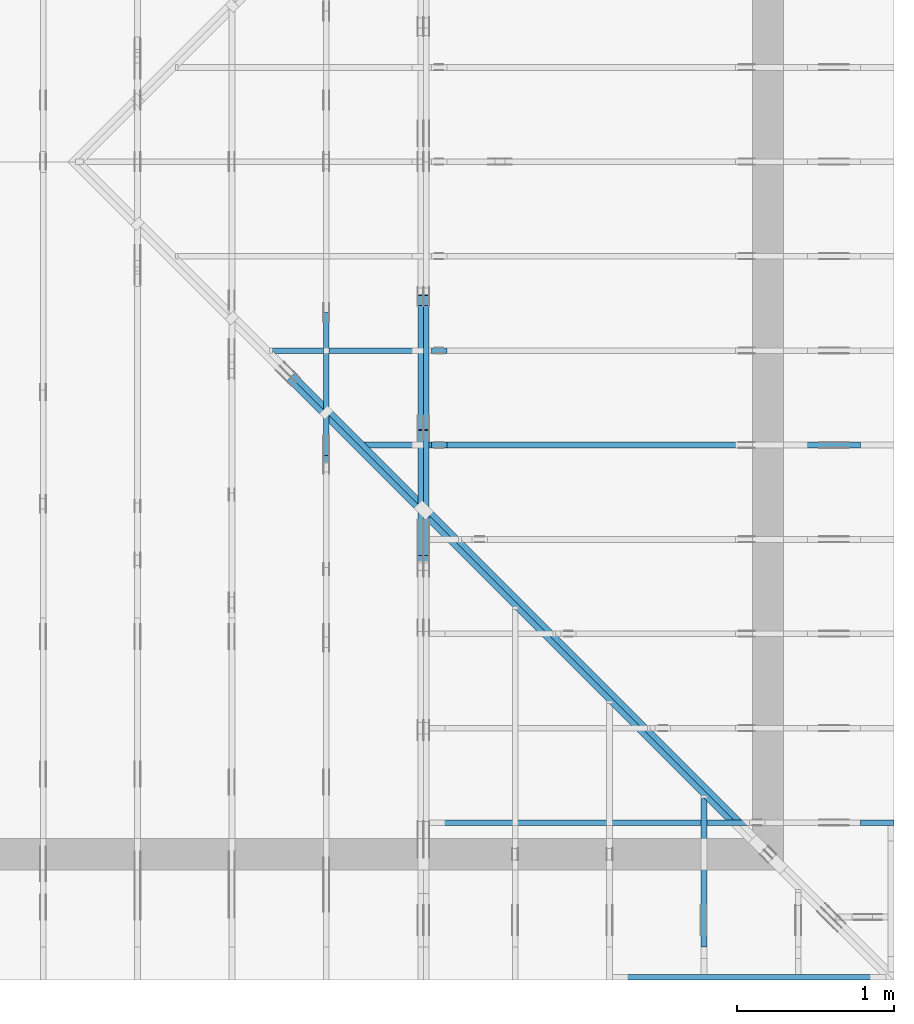
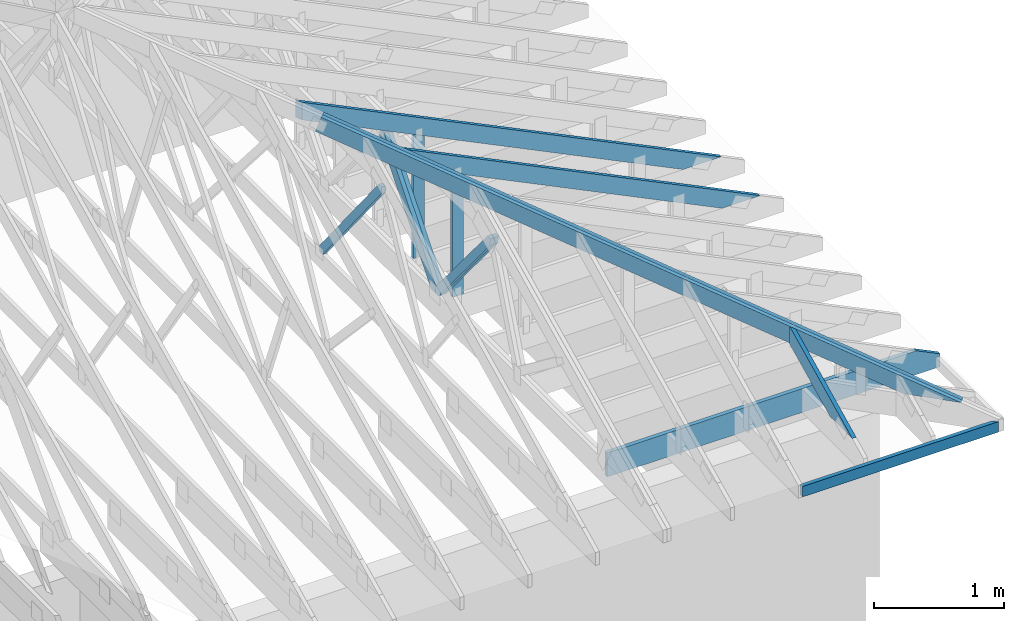
# One storey, part 30 of 159: 14 members, 8 elements without a shape of their own.
"""IFC2X3 building model written with IfcOpenShell, lengths in millimetres."""

from ifc_helpers import new_model, si_unit, frame, origin, origin_with_axes, origin_2d, place, context, project, spatial, faceted_brep, element, aggregate, save


model = new_model("IFC2X3")

# Units and contexts
model_context = context("Model", 3, precision=1e-05, world=origin())
plan_context = context("Plan", 2, precision=1e-05, world=origin_2d())
ifc_project = project(units=[si_unit("LENGTHUNIT", "METRE", prefix="MILLI"), si_unit("AREAUNIT", "SQUARE_METRE"), si_unit("VOLUMEUNIT", "CUBIC_METRE"), si_unit("SOLIDANGLEUNIT", "STERADIAN"), si_unit("PLANEANGLEUNIT", "RADIAN"), si_unit("MASSUNIT", "GRAM"), si_unit("TIMEUNIT", "SECOND"), si_unit("THERMODYNAMICTEMPERATUREUNIT", "DEGREE_CELSIUS"), si_unit("LUMINOUSINTENSITYUNIT", "LUMEN")], contexts=[model_context, plan_context])

# Site, building, storey
site_placement = place(None, origin_with_axes())
site = spatial("IfcSite", under=ifc_project, at=site_placement, CompositionType="ELEMENT")
building_placement = place(site_placement, origin_with_axes())
building = spatial("IfcBuilding", under=site, at=building_placement, Name="Plan 1", CompositionType="ELEMENT")
storey_placement = place(building_placement, origin_with_axes())
storey = spatial("IfcBuildingStorey", under=building, at=storey_placement, Name="Etasje 1", CompositionType="ELEMENT", Elevation=0.0)

# Assembly, members
assembly_1_placement = place(storey_placement, frame((18074.541652722903, -699.9989301294845, 4.408582873760558e-15), z_axis=(-1.0, 1.836909530733566e-16, 6.123031769111886e-17), x_axis=(-1.836909530733566e-16, -1.0, 0.0)))
assembly_1 = element("IfcElementAssembly", 1, at=assembly_1_placement, inside=storey, Name="V5 (30)", AssemblyPlace="FACTORY", PredefinedType="TRUSS")
member_1_placement = place(assembly_1_placement, frame((-2678.1204012406793, 1271.1402097233088, -36.0), z_axis=(0.0, 0.0, 1.0), x_axis=(-0.6383914022226188, -0.7697119055648279, 0.0)))
member_1 = element("IfcMember", 2, at=member_1_placement, Name="V5-D38", context=model_context, shape_type="Brep", body=[
    faceted_brep([(1301.1849955110679, 73.00008611311387, 36.0), (62.15342317344346, 73.00008611311387, 36.0), (1.925760545873345e-05, 36.500065057071424, 36.0), (30.2728013912257, 1.0793038654810516e-05, 36.0), (1274.7302246285853, 1.0793038654810516e-05, 36.0), (1331.4577776446881, 36.500065057071424, 36.0), (62.15342317344346, 73.00008611311387, 7.611347693000984e-15), (1301.1849955110679, 73.00008611311387, 1.5934394130011952e-13), (1331.4577776446881, 36.500065057071424, 1.630511654349907e-13), (1274.7302246285853, 1.0793038654810516e-05, 1.561042732489592e-13), (30.2728013912257, 1.0793038654810516e-05, 3.707226493169789e-15), (1.925760545873345e-05, 36.500065057071424, 2.358298600416948e-21), (-3.552713678800501e-15, 36.500040380931296, 3.944304526105059e-31), (-1.7763568394002505e-15, 36.500040380931296, 36.0), (62.15334871144181, 73.00004038003819, 36.0), (62.15334871144181, 73.00004038003819, 1.9721522630525295e-30), (30.272737128310837, 4.038003907957943e-05, -1.9721522630525295e-31), (30.27273712831084, 4.038003908135579e-05, 36.0), (-3.552713678800501e-15, 36.50004038093129, 36.0), (-3.552713678800501e-15, 36.50004038093129, 3.944304526105059e-31), (1274.7301805652774, 4.038003774819817e-05, -1.9033096714954924e-30), (1274.7301805652774, 4.0380037750402464e-05, 36.0), (30.272737128310837, 4.038003908429828e-05, 36.0), (30.272737128310837, 4.038003908209399e-05, -4.520029685691473e-32), (1331.4577705691959, 36.50004038003976, -1.9644201173045402e-29), (1331.4577705691959, 36.50004038003976, 36.0), (1274.7301805652774, 4.038003805817425e-05, 36.0), (1274.7301805652774, 4.038003805817425e-05, -1.9228473416014148e-29), (1301.1850334416263, 73.00004038003783, 0.0), (1301.1850334416263, 73.00004038003783, 36.0), (1331.4577705691959, 36.500040380039536, 36.0), (1331.4577705691959, 36.500040380039536, 0.0), (62.15334871144182, 73.00004038003819, 1.5777218104420236e-30), (62.15334871144182, 73.00004038003819, 36.0), (1301.1850334416263, 73.00004038003783, 36.0), (1301.1850334416263, 73.00004038003783, 7.099748146989106e-30)], [[[0, 1, 2, 3, 4, 5]], [[6, 7, 8, 9, 10, 11]], [[12, 13, 14, 15]], [[16, 17, 18, 19]], [[20, 21, 22, 23]], [[24, 25, 26, 27]], [[28, 29, 30, 31]], [[32, 33, 34, 35]]]),
])
member_2_placement = place(assembly_1_placement, frame((-2678.1204012406793, 1271.1402097233088, -72.0), z_axis=(0.0, 0.0, 1.0), x_axis=(-0.6383914022226188, -0.7697119055648279, 0.0)))
member_2 = element("IfcMember", 3, at=member_2_placement, Name="V5-D38", context=model_context, shape_type="Brep", body=[
    faceted_brep([(1301.1849955110679, 73.00008611311387, 36.0), (62.15342317344346, 73.00008611311387, 36.0), (1.925760545873345e-05, 36.500065057071424, 36.0), (30.2728013912257, 1.0793038654810516e-05, 36.0), (1274.7302246285853, 1.0793038654810516e-05, 36.0), (1331.4577776446881, 36.500065057071424, 36.0), (62.15342317344346, 73.00008611311387, 7.611347693000984e-15), (1301.1849955110679, 73.00008611311387, 1.5934394130011952e-13), (1331.4577776446881, 36.500065057071424, 1.630511654349907e-13), (1274.7302246285853, 1.0793038654810516e-05, 1.561042732489592e-13), (30.2728013912257, 1.0793038654810516e-05, 3.707226493169789e-15), (1.925760545873345e-05, 36.500065057071424, 2.358298600416948e-21), (-3.552713678800501e-15, 36.500040380931296, 3.944304526105059e-31), (-1.7763568394002505e-15, 36.500040380931296, 36.0), (62.15334871144181, 73.00004038003819, 36.0), (62.15334871144181, 73.00004038003819, 1.9721522630525295e-30), (30.272737128310837, 4.038003907957943e-05, -1.9721522630525295e-31), (30.27273712831084, 4.038003908135579e-05, 36.0), (-3.552713678800501e-15, 36.50004038093129, 36.0), (-3.552713678800501e-15, 36.50004038093129, 3.944304526105059e-31), (1274.7301805652774, 4.038003774819817e-05, -1.9033096714954924e-30), (1274.7301805652774, 4.0380037750402464e-05, 36.0), (30.272737128310837, 4.038003908429828e-05, 36.0), (30.272737128310837, 4.038003908209399e-05, -4.520029685691473e-32), (1331.4577705691959, 36.50004038003976, -1.9644201173045402e-29), (1331.4577705691959, 36.50004038003976, 36.0), (1274.7301805652774, 4.038003805817425e-05, 36.0), (1274.7301805652774, 4.038003805817425e-05, -1.9228473416014148e-29), (1301.1850334416263, 73.00004038003783, 0.0), (1301.1850334416263, 73.00004038003783, 36.0), (1331.4577705691959, 36.500040380039536, 36.0), (1331.4577705691959, 36.500040380039536, 0.0), (62.15334871144182, 73.00004038003819, 1.5777218104420236e-30), (62.15334871144182, 73.00004038003819, 36.0), (1301.1850334416263, 73.00004038003783, 36.0), (1301.1850334416263, 73.00004038003783, 7.099748146989106e-30)], [[[0, 1, 2, 3, 4, 5]], [[6, 7, 8, 9, 10, 11]], [[12, 13, 14, 15]], [[16, 17, 18, 19]], [[20, 21, 22, 23]], [[24, 25, 26, 27]], [[28, 29, 30, 31]], [[32, 33, 34, 35]]]),
])
member_3_placement = place(assembly_1_placement, frame((-4387.724314539022, 1216.557586970512, -36.0), z_axis=(0.0, 0.0, 1.0), x_axis=(0.6383914022217934, -0.7697119055655125, 0.0)))
member_3 = element("IfcMember", 4, at=member_3_placement, Name="V5-D8", context=model_context, shape_type="Brep", body=[
    faceted_brep([(1285.0975247561496, 98.00015613100459, 36.0), (40.640101518789834, 98.00015613100459, 36.0), (5.104694082547212e-06, 49.00016516084588, 36.0), (46.3601114727885, 0.0, 36.0), (1290.8176670776807, 0.0, 36.0), (1331.4577634917764, 49.00016516084588, 36.0), (40.640101518789834, 98.00015613100459, 4.9768126539896475e-15), (1285.0975247561496, 98.00015613100459, 1.5737385940977904e-13), (1331.4577634917764, 49.00016516084588, 1.6305116370181615e-13), (1290.8176670776807, 0.0, 1.580743516729506e-13), (46.3601114727885, 0.0, 5.6772887073490485e-15), (5.104694082547212e-06, 49.00016516084588, 6.251240807806807e-22), (0.0, 49.00020690122301, 0.0), (0.0, 49.00020690122301, 36.0), (40.640112856102874, 98.00020690122393, 36.0), (40.640112856102874, 98.00020690122393, 0.0), (46.36021427532477, 0.00020690122345712325, 7.888609052210118e-31), (46.36021427532477, 0.00020690122345712325, 36.0), (7.105427357601002e-15, 49.000206901223024, 36.0), (7.105427357601002e-15, 49.000206901223024, -7.888609052210118e-31), (1290.8176577111703, 0.0002069012265310194, 3.4974028644761074e-29), (1290.8176577111703, 0.0002069012265332237, 36.0), (46.36021427532478, 0.0002069012234459185, 36.0), (46.36021427532478, 0.00020690122344371422, 1.2561065560570457e-30), (1331.4577705673223, 49.0002069011648, 0.0), (1331.4577705673223, 49.0002069011648, 36.0), (1290.8176577111703, 0.00020690122710220749, 36.0), (1290.8176577111703, 0.00020690122710220749, 1.262177448353619e-29), (1285.097556291957, 98.00020690122653, -5.004461676197e-30), (1285.097556291957, 98.00020690122653, 36.0), (1331.4577705673223, 49.00020690116469, 36.0), (1331.4577705673223, 49.00020690116469, -5.420189433228759e-30), (40.64011285610286, 98.00020690122392, 0.0), (40.64011285610286, 98.00020690122392, 36.0), (1285.097556291957, 98.0002069012266, 36.0), (1285.097556291957, 98.0002069012266, -2.3665827156630354e-30)], [[[0, 1, 2, 3, 4, 5]], [[6, 7, 8, 9, 10, 11]], [[12, 13, 14, 15]], [[16, 17, 18, 19]], [[20, 21, 22, 23]], [[24, 25, 26, 27]], [[28, 29, 30, 31]], [[32, 33, 34, 35]]]),
])
member_4_placement = place(assembly_1_placement, frame((-4387.724314539022, 1216.557586970512, -72.0), z_axis=(0.0, 0.0, 1.0), x_axis=(0.6383914022217934, -0.7697119055655125, 0.0)))
member_4 = element("IfcMember", 5, at=member_4_placement, Name="V5-D8", context=model_context, shape_type="Brep", body=[
    faceted_brep([(1285.0975247561496, 98.00015613100459, 36.0), (40.640101518789834, 98.00015613100459, 36.0), (5.104694082547212e-06, 49.00016516084588, 36.0), (46.3601114727885, 0.0, 36.0), (1290.8176670776807, 0.0, 36.0), (1331.4577634917764, 49.00016516084588, 36.0), (40.640101518789834, 98.00015613100459, 4.9768126539896475e-15), (1285.0975247561496, 98.00015613100459, 1.5737385940977904e-13), (1331.4577634917764, 49.00016516084588, 1.6305116370181615e-13), (1290.8176670776807, 0.0, 1.580743516729506e-13), (46.3601114727885, 0.0, 5.6772887073490485e-15), (5.104694082547212e-06, 49.00016516084588, 6.251240807806807e-22), (0.0, 49.00020690122301, 0.0), (0.0, 49.00020690122301, 36.0), (40.640112856102874, 98.00020690122393, 36.0), (40.640112856102874, 98.00020690122393, 0.0), (46.36021427532477, 0.00020690122345712325, 7.888609052210118e-31), (46.36021427532477, 0.00020690122345712325, 36.0), (7.105427357601002e-15, 49.000206901223024, 36.0), (7.105427357601002e-15, 49.000206901223024, -7.888609052210118e-31), (1290.8176577111703, 0.0002069012265310194, 3.4974028644761074e-29), (1290.8176577111703, 0.0002069012265332237, 36.0), (46.36021427532478, 0.0002069012234459185, 36.0), (46.36021427532478, 0.00020690122344371422, 1.2561065560570457e-30), (1331.4577705673223, 49.0002069011648, 0.0), (1331.4577705673223, 49.0002069011648, 36.0), (1290.8176577111703, 0.00020690122710220749, 36.0), (1290.8176577111703, 0.00020690122710220749, 1.262177448353619e-29), (1285.097556291957, 98.00020690122653, -5.004461676197e-30), (1285.097556291957, 98.00020690122653, 36.0), (1331.4577705673223, 49.00020690116469, 36.0), (1331.4577705673223, 49.00020690116469, -5.420189433228759e-30), (40.64011285610286, 98.00020690122392, 0.0), (40.64011285610286, 98.00020690122392, 36.0), (1285.097556291957, 98.0002069012266, 36.0), (1285.097556291957, 98.0002069012266, -2.3665827156630354e-30)], [[[0, 1, 2, 3, 4, 5]], [[6, 7, 8, 9, 10, 11]], [[12, 13, 14, 15]], [[16, 17, 18, 19]], [[20, 21, 22, 23]], [[24, 25, 26, 27]], [[28, 29, 30, 31]], [[32, 33, 34, 35]]]),
])
aggregate(assembly_1, [member_1, member_2, member_3, member_4])

# Assembly, member
assembly_2_placement = place(storey_placement, frame((17475.02226140475, -699.9989301294827, 1.1021457184401395e-15), z_axis=(-1.0, 1.836909530733566e-16, 6.123031769111886e-17), x_axis=(-1.836909530733566e-16, -1.0, 0.0)))
assembly_2 = element("IfcElementAssembly", 6, at=assembly_2_placement, inside=storey, Name="V6 (31)", AssemblyPlace="FACTORY", PredefinedType="TRUSS")
member_5_placement = place(assembly_2_placement, frame((-3313.956030460892, 1580.717350528673, -36.0), z_axis=(0.0, 0.0, 1.0), x_axis=(-0.6278034094760664, -0.7783719413302528, 0.0)))
member_5 = element("IfcMember", 7, at=member_5_placement, Name="V6-D29", context=model_context, shape_type="Brep", body=[
    faceted_brep([(1495.2848439964994, 72.9998961038782, 36.0), (54.10332463457826, 72.9998961038782, 36.0), (0.0, 36.50005710134883, 36.0), (29.439473698314487, 0.0, 36.0), (1479.470225956314, 0.0, 36.0), (1524.7241644224976, 36.50005710134883, 36.0), (54.10332463457826, 72.9998961038782, 6.625527511041928e-15), (1495.2848439964994, 72.9998961038782, 1.8311353207324154e-13), (1524.7241644224976, 36.50005710134883, 1.8671868995783056e-13), (1479.470225956314, 0.0, 1.81176863899713e-13), (29.439473698314487, 0.0, 3.605176654414268e-15), (0.0, 36.50005710134883, 0.0), (1.3237788607511902e-05, 36.50003824703937, 3.94430452610506e-31), (1.3237788607511902e-05, 36.50003824703937, 36.0), (54.10342094691692, 73.00003824676244, 36.0), (54.10342094691692, 73.00003824676244, 7.888609052210118e-31), (29.439440880682014, 3.824676195662846e-05, -3.111202796798486e-31), (29.439440880682017, 3.824676195840482e-05, 36.0), (1.3237788618170043e-05, 36.50003824703936, 36.0), (1.3237788618170043e-05, 36.50003824703936, -6.1376708085896054e-31), (1479.4702201235507, 3.8246764242622385e-05, 8.299999800625023e-29), (1479.4702201235507, 3.824676424482668e-05, 36.0), (29.439440880682014, 3.8246761935412115e-05, 36.0), (29.439440880682014, 3.8246761933207824e-05, 1.651586866182158e-30), (1524.7241569924536, 36.5000382467623, 1.262177448353619e-29), (1524.7241569924536, 36.5000382467623, 36.0), (1479.470220123551, 3.8246765484473144e-05, 36.0), (1479.470220123551, 3.8246765484473144e-05, 2.524354896707238e-29), (1495.2847293497816, 73.00003824676526, 1.262177448353619e-29), (1495.2847293497816, 73.00003824676526, 36.0), (1524.7241569924536, 36.50003824676253, 36.0), (1524.7241569924536, 36.50003824676253, 1.262177448353619e-29), (54.10342094691692, 73.00003824676241, 7.888609052210118e-31), (54.10342094691692, 73.00003824676241, 36.0), (1495.2847293497814, 73.00003824676521, 36.0), (1495.2847293497814, 73.00003824676521, 4.733165431326071e-30)], [[[0, 1, 2, 3, 4, 5]], [[6, 7, 8, 9, 10, 11]], [[12, 13, 14, 15]], [[16, 17, 18, 19]], [[20, 21, 22, 23]], [[24, 25, 26, 27]], [[28, 29, 30, 31]], [[32, 33, 34, 35]]]),
])
aggregate(assembly_2, [member_5])

assembly_3_placement = place(storey_placement, frame((19911.02226140475, -663.9989301290217, 1.1021457184401395e-15), z_axis=(1.0, -6.123031769111886e-17, 6.123031769111886e-17), x_axis=(6.123031769111886e-17, 1.0, 0.0)))
assembly_3 = element("IfcElementAssembly", 8, at=assembly_3_placement, inside=storey, Name="S22 (54)", AssemblyPlace="FACTORY", PredefinedType="TRUSS")
member_6_placement = place(assembly_3_placement, frame((240.06022270783777, 89.9784794744281, -36.00000021761496), z_axis=(0.0, 0.0, 1.0), x_axis=(0.898794046299167, 0.4383711467890774, 0.0)))
member_6 = element("IfcMember", 9, at=member_6_placement, Name="S22-O69", context=model_context, shape_type="Brep", body=[
    faceted_brep([(1071.3215366312243, 148.00000083084953, 2.2534031813847832e-06), (1031.2678696339153, 147.99999513787262, 35.999997187478755), (959.0834456828859, 3.2114098758029286e-07, 36.00000021761497), (999.1371156253897, -5.684341886080802e-14, 5.684341886080802e-14), (4.652467617916045e-05, 148.00000032046006, 2.1761496071803774e-07), (4.652467617916045e-05, 148.00000032046, 36.00000021761496), (1031.2678687903012, 148.00000032045995, 36.00000021761496), (1071.3215377661313, 148.00000032046, 2.1761496071803774e-07), (303.44497171313134, 3.2077181799650134e-07, 2.1761496071803776e-07), (303.44497171313134, 3.2077181799650134e-07, 36.00000021761496), (1.4210854715202004e-14, 148.0000018617121, 36.00000021761496), (1.4210854715202004e-14, 148.0000018617121, 2.1761496071803776e-07), (999.137115539915, 3.211633869099424e-07, 2.1761496071803774e-07), (959.0834465640852, 3.211634604205767e-07, 36.00000021761496), (303.44497686804016, 3.2116358085543203e-07, 36.00000021761496), (303.44497686804016, 3.211635147022944e-07, 2.1761496071803774e-07), (1031.2678710368896, 148.00000032114116, 36.00000021761496), (1.062429183207314e-05, 148.00000032114116, 36.00000021761496), (303.4449569133543, 3.207719885267579e-07, 36.00000021761496), (959.0834456828858, 3.207719885267579e-07, 36.00000021761496), (5.444185717351502e-06, 148.0000003209197, 2.1761496071803843e-07), (1071.3215386473107, 148.0000003209197, 2.176150919127541e-07), (999.1371132933069, 3.204421545888181e-07, 2.1761508307300348e-07), (303.44495173324833, 3.204421545888181e-07, 2.1761499787809936e-07)], [[[0, 1, 2, 3]], [[4, 5, 6, 7]], [[8, 9, 10, 11]], [[12, 13, 14, 15]], [[16, 17, 18, 19]], [[20, 21, 22, 23]]]),
])
aggregate(assembly_3, [member_6])

assembly_4_placement = place(storey_placement, frame((21100.012663101486, 318.00740142125824, 1.1021457184401395e-15), z_axis=(1.2246063538223773e-16, 1.0, 6.123031769111886e-17), x_axis=(-1.0, 1.2246063538223773e-16, 0.0)))
assembly_4 = element("IfcElementAssembly", 10, at=assembly_4_placement, inside=storey, Name="S20 (44)", AssemblyPlace="FACTORY", PredefinedType="TRUSS")
member_7_placement = place(assembly_4_placement, frame((2953.4710103785837, 223.0, -36.0), z_axis=(0.0, 0.0, 1.0), x_axis=(-1.0, 1.2246063538223773e-16, 0.0)))
member_7 = element("IfcMember", 11, at=member_7_placement, Name="S20-U10", context=model_context, shape_type="Brep", body=[
    faceted_brep([(2953.4710103785947, 223.00000000000037, 36.0), (6.311295874183998e-05, 223.00000000000037, 36.0), (6.311295874183998e-05, 0.0, 36.0), (2742.289720705732, 0.0, 36.0), (2953.4700660270973, 102.9995422363285, 36.0), (6.311295874183998e-05, 223.00000000000037, 7.728853028378678e-21), (2953.4710103785947, 223.00000000000037, 3.616839365139823e-13), (2953.4700660270973, 102.9995422363285, 3.6168382086809796e-13), (2742.289720705732, 0.0, 3.358225415998032e-13), (6.311295874183998e-05, 0.0, 7.728853028378678e-21), (0.0, 0.0, 0.0), (2.204291436880279e-15, -2.6993892992798474e-31, 36.0), (2.951301312711929e-14, 223.0, 36.0), (2.7308721690239013e-14, 223.0, -1.6721217048316832e-30), (2742.2897146949763, -5.037338112955833e-13, 5.172702487036636e-29), (2742.2897146949763, -5.01529519858703e-13, 36.0), (4.049083948919771e-31, 2.204291436880279e-15, 36.0), (0.0, 0.0, 0.0), (2953.4700660271083, 102.9995394088487, -7.573064690121713e-29), (2953.4700660271083, 102.9995394088487, 36.0), (2742.289714694976, 1.1368683772161603e-12, 36.0), (2742.289714694976, 1.1368683772161603e-12, -6.310887241768094e-29), (2953.4692552825763, 223.00000000000037, -1.0746508677980613e-19), (2953.4692552825763, 223.00000000000037, 36.0), (2953.4692552825763, 102.99953940884771, 36.0), (2953.4692552825763, 102.99953940884771, -4.9642145257273734e-20), (0.0, 223.0, 0.0), (0.0, 223.0, 36.0), (2953.4710103785947, 223.00000000000048, 36.0), (2953.4710103785947, 223.00000000000048, 6.310887241768095e-30)], [[[0, 1, 2, 3, 4]], [[5, 6, 7, 8, 9]], [[10, 11, 12, 13]], [[14, 15, 16, 17]], [[18, 19, 20, 21]], [[22, 23, 24, 25]], [[26, 27, 28, 29]]]),
])
aggregate(assembly_4, [member_7])

# Assembly, members
assembly_5_placement = place(storey_placement, frame((21100.012663101486, 3318.0074014212582, 1.1021457184401395e-15), z_axis=(1.2246063538223773e-16, 1.0, 6.123031769111886e-17), x_axis=(-1.0, 1.2246063538223773e-16, 0.0)))
assembly_5 = element("IfcElementAssembly", 12, at=assembly_5_placement, inside=storey, Name="S15 (41)", AssemblyPlace="FACTORY", PredefinedType="TRUSS")
member_8_placement = place(assembly_5_placement, frame((276.06022256912524, 89.97847976264961, -36.00000021761038), z_axis=(0.0, 0.0, 1.0), x_axis=(0.8987940462991673, 0.43837114678907696, 0.0)))
member_8 = element("IfcMember", 13, at=member_8_placement, Name="S15-O20", context=model_context, shape_type="Brep", body=[
    faceted_brep([(4178.836482823181, 147.99999481745965, 36.00000324784287), (4106.6520588721505, 7.27482074580621e-10, 36.00000021761025), (4066.598388929642, 3.2189416288019856e-07, -6.821210263296962e-13), (4138.782812880672, 147.99999513862542, 3.0302319373731734e-06), (5.619829465786097e-05, 148.00000000000585, 2.1761037061196475e-07), (5.619829465786097e-05, 148.00000000000585, 36.00000021761038), (4178.836481979545, 148.00000000000654, 36.00000021761038), (4138.782813003715, 148.0000000000065, 2.1761037061196475e-07), (9.72786922375235e-05, 147.99999999942776, 2.1761037061197667e-07), (4138.782812122442, 147.99999999942776, 2.1761087744993763e-07), (4066.598386768439, 0.0, 2.1761086861018705e-07), (303.4449214974421, 0.0, 2.1761040777202264e-07), (303.44497171313145, 9.617906471248716e-11, 2.1761037061196475e-07), (303.44497171313145, 9.617906471248716e-11, 36.00000021761037), (0.0, 148.0000015410362, 36.00000021761037), (0.0, 148.0000015410362, 2.1761037061196475e-07), (4106.6520579908765, 7.198564539768643e-10, 36.00000021761037), (303.44506870254645, 7.205550686934619e-10, 36.00000021761037), (303.44506870254645, 7.20552864402025e-10, 2.1761037061196475e-07), (4066.5983890150465, 7.198616071820557e-10, 2.1761037061196475e-07), (4178.8364842261535, 148.00000000072714, 36.00000021761037), (0.00020340339943913932, 148.00000000072714, 36.00000021761037), (303.44502762214927, 9.632117325963918e-11, 36.00000021761037), (4106.65205887215, 9.632117325963918e-11, 36.00000021761037)], [[[0, 1, 2, 3]], [[4, 5, 6, 7]], [[8, 9, 10, 11]], [[12, 13, 14, 15]], [[16, 17, 18, 19]], [[20, 21, 22, 23]]]),
])
member_9_placement = place(assembly_5_placement, frame((2840.990401698568, 1388.7763671875, -36.0), z_axis=(0.0, 0.0, 1.0), x_axis=(-1.836909530733566e-16, -1.0, 0.0)))
member_9 = element("IfcMember", 14, at=member_9_placement, Name="S15-S8", context=model_context, shape_type="Brep", body=[
    faceted_brep([(1165.7763671875, 98.00007681705756, 36.0), (0.0, 98.00007681705756, 36.0), (47.7978515625, 7.681705710638198e-05, 36.0), (1165.7763671875, 7.681705710638198e-05, 36.0), (0.0, 98.00007681705756, 0.0), (1165.7763671875, 98.00007681705756, 1.4276171463937812e-13), (1165.7763671875, 7.681705710638198e-05, 1.4276171463937812e-13), (47.7978515625, 7.681705710638198e-05, 5.853355272249634e-15), (47.79785166681542, 1.4100720591159188e-11, -1.247858387398912e-30), (47.79785166681542, 1.4100720591159188e-11, 36.0), (5.7987337655163174e-05, 98.0000000000141, 36.0), (5.7987337655163174e-05, 98.0000000000141, -1.306298835932967e-30), (1165.776367187592, -1.0110684919648689e-14, 6.190804497048674e-31), (1165.776367187592, -7.90639348276841e-15, 36.0), (47.797851666815404, 1.4098957621983875e-11, 36.0), (47.797851666815404, 1.4096753330546995e-11, 2.5382840429444347e-32), (1165.776367187592, 97.99999999998545, 3.736045247126712e-27), (1165.776367187592, 97.99999999998545, 36.0), (1165.776367187592, 0.0, 36.0), (1165.776367187592, 0.0, 0.0), (5.798733764095232e-05, 98.0000000000141, 0.0), (5.798733764095232e-05, 98.0000000000141, 36.0), (1165.7763671875312, 97.99999999998555, 36.0), (1165.7763671875312, 97.99999999998555, 6.310887241768095e-30)], [[[0, 1, 2, 3]], [[4, 5, 6, 7]], [[8, 9, 10, 11]], [[12, 13, 14, 15]], [[16, 17, 18, 19]], [[20, 21, 22, 23]]]),
])
aggregate(assembly_5, [member_8, member_9])

assembly_6_placement = place(storey_placement, frame((21100.012663101486, 2718.0074014212582, 1.1021457184401395e-15), z_axis=(1.2246063538223773e-16, 1.0, 6.123031769111886e-17), x_axis=(-1.0, 1.2246063538223773e-16, 0.0)))
assembly_6 = element("IfcElementAssembly", 15, at=assembly_6_placement, inside=storey, Name="S16 (39)", AssemblyPlace="FACTORY", PredefinedType="TRUSS")
member_10_placement = place(assembly_6_placement, frame((276.060157019976, 89.97844779167221, -36.000000217588955), z_axis=(0.0, 0.0, 1.0), x_axis=(0.8987940462991673, 0.43837114678907685, 0.0)))
member_10 = element("IfcMember", 16, at=member_10_placement, Name="S16-O30", context=model_context, shape_type="Brep", body=[
    faceted_brep([(3511.2753914678674, 147.99999481670773, 36.000003247793984), (3439.0909675167886, 0.0, 36.00000021758888), (3399.0372975742603, 3.2118248327606125e-07, -4.547473508864641e-13), (3471.22172152534, 147.99999513789032, 3.0302053346531466e-06), (1.1368683772161603e-13, 148.00000000095264, 2.1758895485390892e-07), (1.1368683772161605e-13, 148.00000000095287, 36.000000217588955), (3511.275390625, 148.00000000095264, 36.000000217588955), (3471.22172164917, 148.00000000095244, 2.1758895485390892e-07), (4.1080394396431075e-05, 147.99999999989603, 2.1758895485391397e-07), (3471.221720767894, 147.99999999989603, 2.1758937994192642e-07), (3399.0372954138907, 9.40644895308651e-10, 2.1758937110217584e-07), (303.44510943976934, 9.40644895308651e-10, 2.1758899201398986e-07), (303.4450446434704, 5.64412516723678e-10, 2.1758895485390894e-07), (303.4450446434704, 5.64412516723678e-10, 36.000000217588955), (7.293033915800606e-05, 148.00000154150464, 36.000000217588955), (7.293033915800606e-05, 148.00000154150464, 2.1758895485390894e-07), (3439.090966635522, 6.584016521011452e-12, 36.000000217588955), (303.4450125034416, 7.160006314826589e-12, 36.000000217588955), (303.4450125034416, 7.157802023389708e-12, 2.1758895485390894e-07), (3399.0372976596914, 6.589169726202827e-12, 2.1758895485390894e-07), (3511.2753928707916, 148.00000000000023, 36.000000217588955), (0.00014720428777081906, 148.00000000000023, 36.000000217588955), (303.44497142303794, 5.646825229632668e-10, 36.000000217588955), (3439.090967516788, 5.646825229632668e-10, 36.000000217588955)], [[[0, 1, 2, 3]], [[4, 5, 6, 7]], [[8, 9, 10, 11]], [[12, 13, 14, 15]], [[16, 17, 18, 19]], [[20, 21, 22, 23]]]),
])
member_11_placement = place(assembly_6_placement, frame((2840.990401698568, 1388.7763671875, -36.0), z_axis=(0.0, 0.0, 1.0), x_axis=(-1.836909530733566e-16, -1.0, 0.0)))
member_11 = element("IfcMember", 17, at=member_11_placement, Name="S16-S8", context=model_context, shape_type="Brep", body=[
    faceted_brep([(1165.7763671875, 98.00007681705756, 36.0), (0.0, 98.00007681705756, 36.0), (47.7978515625, 7.681705710638198e-05, 36.0), (1165.7763671875, 7.681705710638198e-05, 36.0), (0.0, 98.00007681705756, 0.0), (1165.7763671875, 98.00007681705756, 1.4276171463937812e-13), (1165.7763671875, 7.681705710638198e-05, 1.4276171463937812e-13), (47.7978515625, 7.681705710638198e-05, 5.853355272249634e-15), (47.79785166781221, 1.4090062450122787e-11, 3.944304526105059e-31), (47.79785166781221, 1.4090062450122787e-11, 36.0), (5.7988370848249815e-05, 98.00000000001414, 36.0), (5.7988370848249815e-05, 98.00000000001414, -1.9721522630525295e-30), (1165.776367187592, -1.0110684906543046e-14, 6.19080448902383e-31), (1165.776367187592, -7.906393469662767e-15, 36.0), (47.79785166781221, 1.4098957621984403e-11, 36.0), (47.79785166781221, 1.4096753330547523e-11, 2.538284039715843e-32), (1165.776367187592, 97.99999999998545, 3.736045247126712e-27), (1165.776367187592, 97.99999999998545, 36.0), (1165.776367187592, 0.0, 36.0), (1165.776367187592, 0.0, 0.0), (5.798837082693353e-05, 98.0000000000141, 0.0), (5.798837082693353e-05, 98.0000000000141, 36.0), (1165.7763671875312, 97.99999999998555, 36.0), (1165.7763671875312, 97.99999999998555, 6.310887241768095e-30)], [[[0, 1, 2, 3]], [[4, 5, 6, 7]], [[8, 9, 10, 11]], [[12, 13, 14, 15]], [[16, 17, 18, 19]], [[20, 21, 22, 23]]]),
])
aggregate(assembly_6, [member_10, member_11])

assembly_7_placement = place(storey_placement, frame((21125.46850722421, -674.5430860067681, 2.204291436880279e-15), z_axis=(0.707106781186546, 0.707106781186549, 6.123031769111886e-17), x_axis=(-0.707106781186549, 0.707106781186546, 0.0)))
assembly_7 = element("IfcElementAssembly", 18, at=assembly_7_placement, inside=storey, Name="GR1 (35)", AssemblyPlace="FACTORY", PredefinedType="TRUSS")
member_12_placement = place(assembly_7_placement, frame((382.90850618663825, 83.08701368323861, -36.00000195234117), z_axis=(0.0, 0.0, 1.0), x_axis=(0.9453579955214152, 0.32603413978252627, 0.0)))
member_12 = element("IfcMember", 19, at=member_12_placement, Name="GR1-O2", context=model_context, shape_type="Brep", body=[
    faceted_brep([(9.094947017729282e-13, 148.00000315181347, 1.952341179389805e-06), (9.094947017729282e-13, 148.00000315181347, 36.00000195234118), (5380.000000000001, 148.00000315181313, 36.00000195234118), (5380.000000000001, 148.00000315181313, 1.952341179389805e-06), (429.13598996492084, 3.151003625134763e-06, 1.952341179389805e-06), (429.13598996492084, 3.151003625134763e-06, 36.00000195234118), (6.069707794154056e-06, 148.00000105849915, 36.00000195234118), (6.069707794154056e-06, 148.00000105849915, 1.952341179389805e-06), (5379.999999999999, 3.1509182713895772e-06, 1.952341179389805e-06), (5379.999999999999, 3.1509182735938687e-06, 36.00000195234118), (429.1362304687506, 3.150919183022753e-06, 36.00000195234118), (429.1362304687506, 3.1509191808184616e-06, 1.952341179389805e-06), (5380.0, 148.00000277524896, 1.8783536717137395e-06), (5379.999999999999, 148.00000277524896, 36.00000195234118), (5379.999999999999, 0.0, 36.00000255341424), (5380.0, 0.0, 0.0), (5379.999999999999, 148.00000315091938, 36.00000195234118), (4.547473508864641e-13, 148.00000315091938, 36.00000195234118), (429.1362304687506, 3.151003227230831e-06, 36.00000195234118), (5379.999999999999, 3.151003227230831e-06, 36.00000195234118), (0.0, 148.0000031518136, 1.952341179389805e-06), (5379.999999999999, 148.0000031518136, 1.9523418382280232e-06), (5380.0, 3.150919837935362e-06, 1.9523418382280232e-06), (429.1362304687497, 3.150919837935362e-06, 1.9523412319421e-06)], [[[0, 1, 2, 3]], [[4, 5, 6, 7]], [[8, 9, 10, 11]], [[12, 13, 14, 15]], [[16, 17, 18, 19]], [[20, 21, 22, 23]]]),
])
member_13_placement = place(assembly_7_placement, frame((382.90850618663825, 83.08701368323861, -72.00000195234118), z_axis=(0.0, 0.0, 1.0), x_axis=(0.9453579955214152, 0.32603413978252627, 0.0)))
member_13 = element("IfcMember", 20, at=member_13_placement, Name="GR1-O2", context=model_context, shape_type="Brep", body=[
    faceted_brep([(9.094947017729282e-13, 148.00000315181347, 1.952341179389805e-06), (9.094947017729282e-13, 148.00000315181347, 36.00000195234118), (5380.000000000001, 148.00000315181313, 36.00000195234118), (5380.000000000001, 148.00000315181313, 1.952341179389805e-06), (429.13598996492084, 3.151003625134763e-06, 1.952341179389805e-06), (429.13598996492084, 3.151003625134763e-06, 36.00000195234118), (6.069707794154056e-06, 148.00000105849915, 36.00000195234118), (6.069707794154056e-06, 148.00000105849915, 1.952341179389805e-06), (5379.999999999999, 3.1509182713895772e-06, 1.952341179389805e-06), (5379.999999999999, 3.1509182735938687e-06, 36.00000195234118), (429.1362304687506, 3.150919183022753e-06, 36.00000195234118), (429.1362304687506, 3.1509191808184616e-06, 1.952341179389805e-06), (5380.0, 148.00000277524896, 1.8783536717137395e-06), (5379.999999999999, 148.00000277524896, 36.00000195234118), (5379.999999999999, 0.0, 36.00000255341424), (5380.0, 0.0, 0.0), (5379.999999999999, 148.00000315091938, 36.00000195234118), (4.547473508864641e-13, 148.00000315091938, 36.00000195234118), (429.1362304687506, 3.151003227230831e-06, 36.00000195234118), (5379.999999999999, 3.151003227230831e-06, 36.00000195234118), (0.0, 148.0000031518136, 1.952341179389805e-06), (5379.999999999999, 148.0000031518136, 1.9523418382280232e-06), (5380.0, 3.150919837935362e-06, 1.9523418382280232e-06), (429.1362304687497, 3.150919837935362e-06, 1.9523412319421e-06)], [[[0, 1, 2, 3]], [[4, 5, 6, 7]], [[8, 9, 10, 11]], [[12, 13, 14, 15]], [[16, 17, 18, 19]], [[20, 21, 22, 23]]]),
])
aggregate(assembly_7, [member_12, member_13])

# Assembly, member
assembly_8_placement = place(storey_placement, frame((19311.02226140475, -699.9989301294839, 0.0), z_axis=(0.0, -1.0, 6.123031769111886e-17), x_axis=(1.0, 0.0, 0.0)))
assembly_8 = element("IfcElementAssembly", 21, at=assembly_8_placement, inside=storey, Name="uu3 (1)", AssemblyPlace="FACTORY", PredefinedType="TRUSS")
member_14_placement = place(assembly_8_placement, frame((1738.0787353515625, 98.00000236466228, -36.00000106976019), z_axis=(0.0, 0.0, 1.0), x_axis=(-1.0, 1.2246063538223773e-16, 0.0)))
member_14 = element("IfcMember", 22, at=member_14_placement, Name="uu3-U49", context=model_context, shape_type="Brep", body=[
    faceted_brep([(36.00002297001059, 2.3646622749108354e-06, 1.4210854715202004e-14), (2.190025042381194e-05, 2.3646622793194183e-06, 36.00000106976019), (2.1900250430917367e-05, 98.00000236466228, 36.000001069760195), (36.00002297001061, 98.00000236466228, 7.105427357601002e-15), (1738.078757251813, 2.364661960050075e-06, 1.0697601879883225e-06), (1738.078757251813, 2.364661978241578e-06, 36.00000106976019), (2.1900250430917367e-05, 2.3646622975109175e-06, 36.00000106976019), (36.00002190025043, 2.36466227270654e-06, 1.0697601879883225e-06), (36.00002190025043, 98.00000236466228, 1.069760192396908e-06), (1738.078757251813, 98.00000236466228, 1.0697604008345513e-06), (1738.078757251813, 2.364662492482239e-06, 1.0697604008345513e-06), (36.00002190025043, 2.364662492482239e-06, 1.069760192396908e-06), (2.1900250430917367e-05, 98.00000236466228, 36.00000106976019), (1738.078757251813, 98.00000236466217, 36.00000106976019), (1738.078757251813, 98.00000236466218, 1.0697601879883223e-06), (36.00002190025043, 98.00000236466228, 1.0697601879883223e-06), (1738.0787353515625, 98.0000023463934, 2.0347284106492225e-06), (1738.0787353515625, 98.0000023463934, 36.00000106976019), (1738.0787353515625, 0.0, 36.000002896668846), (1738.0787353515625, 0.0, 3.532793499516629e-06), (1738.0787353515625, 98.00000236466249, 36.00000106976019), (0.0, 98.00000236466249, 36.00000106976019), (0.0, 2.364662293530273e-06, 36.00000106976019), (1738.0787353515625, 2.364662293530273e-06, 36.00000106976019)], [[[0, 1, 2, 3]], [[4, 5, 6, 7]], [[8, 9, 10, 11]], [[12, 13, 14, 15]], [[16, 17, 18, 19]], [[20, 21, 22, 23]]]),
])
aggregate(assembly_8, [member_14])

save(model, "model.ifc")
